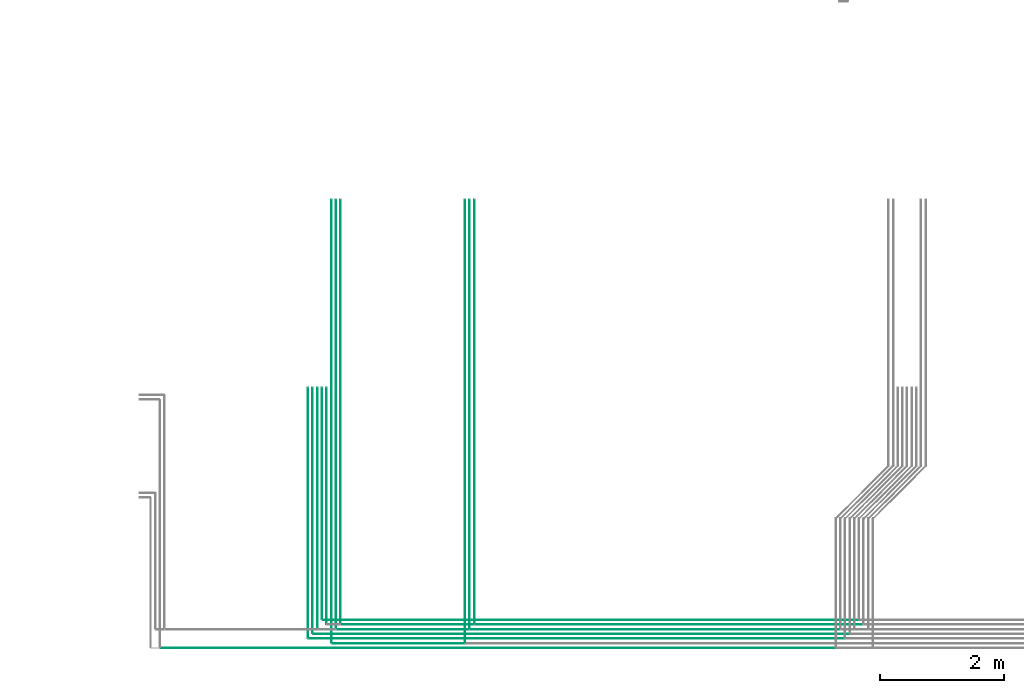
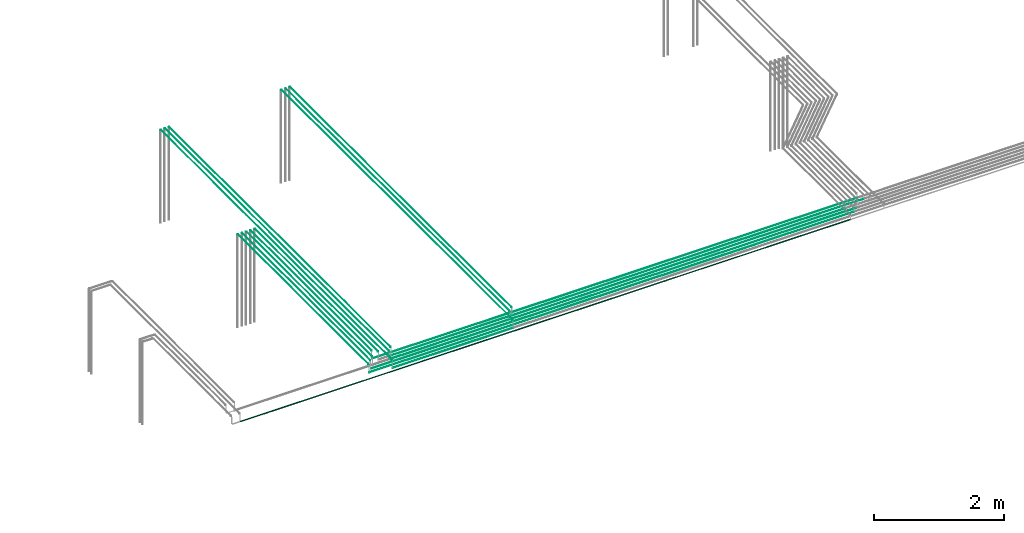
# One storey, part 3 of 89: 20 flow segments.
"""IFC2X3 building model written with IfcOpenShell, lengths in millimetres."""

from ifc_helpers import new_model, entity, si_unit, converted_unit, derived_unit, direction, frame, frame_2d, origin, origin_2d_with_axis, place, context, subcontext, project, spatial, circle, extrude, type_object, element, save


model = new_model("IFC2X3")

# Units and contexts
model_context = context("Model", 3, precision=0.01, world=origin(), true_north=direction((6.12303176911189e-17, 1.0)))
body_context = subcontext(model_context, "Body", "Model", "MODEL_VIEW")
ifc_project = project(units=[si_unit("LENGTHUNIT", "METRE", prefix="MILLI"), si_unit("AREAUNIT", "SQUARE_METRE"), si_unit("VOLUMEUNIT", "CUBIC_METRE"), converted_unit("PLANEANGLEUNIT", "DEGREE", entity("IfcRatioMeasure", 0.0174532925199433), si_unit("PLANEANGLEUNIT", "RADIAN"), dimensions=[0, 0, 0, 0, 0, 0, 0]), si_unit("MASSUNIT", "GRAM", prefix="KILO"), derived_unit("MASSDENSITYUNIT", [(si_unit("MASSUNIT", "GRAM", prefix="KILO"), 1), (si_unit("LENGTHUNIT", "METRE"), -3)]), derived_unit("MOMENTOFINERTIAUNIT", [(si_unit("LENGTHUNIT", "METRE"), 4)]), si_unit("TIMEUNIT", "SECOND"), si_unit("FREQUENCYUNIT", "HERTZ"), si_unit("THERMODYNAMICTEMPERATUREUNIT", "DEGREE_CELSIUS"), derived_unit("THERMALTRANSMITTANCEUNIT", [(si_unit("MASSUNIT", "GRAM", prefix="KILO"), 1), (si_unit("THERMODYNAMICTEMPERATUREUNIT", "KELVIN"), -1), (si_unit("TIMEUNIT", "SECOND"), -3)]), derived_unit("VOLUMETRICFLOWRATEUNIT", [(si_unit("LENGTHUNIT", "METRE"), 3), (si_unit("TIMEUNIT", "SECOND"), -1)]), derived_unit("MASSFLOWRATEUNIT", [(si_unit("MASSUNIT", "GRAM", prefix="KILO"), 1), (si_unit("TIMEUNIT", "SECOND"), -1)]), derived_unit("ROTATIONALFREQUENCYUNIT", [(si_unit("TIMEUNIT", "SECOND"), -1)]), si_unit("ELECTRICCURRENTUNIT", "AMPERE"), si_unit("ELECTRICVOLTAGEUNIT", "VOLT"), si_unit("POWERUNIT", "WATT"), si_unit("FORCEUNIT", "NEWTON", prefix="KILO"), si_unit("ILLUMINANCEUNIT", "LUX"), si_unit("LUMINOUSFLUXUNIT", "LUMEN"), si_unit("LUMINOUSINTENSITYUNIT", "CANDELA"), derived_unit("USERDEFINED", [(si_unit("MASSUNIT", "GRAM", prefix="KILO"), -1), (si_unit("LENGTHUNIT", "METRE"), -2), (si_unit("TIMEUNIT", "SECOND"), 3), (si_unit("LUMINOUSFLUXUNIT", "LUMEN"), 1)]), derived_unit("LINEARVELOCITYUNIT", [(si_unit("LENGTHUNIT", "METRE"), 1), (si_unit("TIMEUNIT", "SECOND"), -1)]), si_unit("PRESSUREUNIT", "PASCAL"), derived_unit("USERDEFINED", [(si_unit("LENGTHUNIT", "METRE"), -2), (si_unit("MASSUNIT", "GRAM", prefix="KILO"), 1), (si_unit("TIMEUNIT", "SECOND"), -2)]), derived_unit("LINEARFORCEUNIT", [(si_unit("MASSUNIT", "GRAM", prefix="KILO"), 1), (si_unit("LENGTHUNIT", "METRE"), 1), (si_unit("TIMEUNIT", "SECOND"), -2), (si_unit("LENGTHUNIT", "METRE"), -1)]), derived_unit("PLANARFORCEUNIT", [(si_unit("MASSUNIT", "GRAM", prefix="KILO"), 1), (si_unit("LENGTHUNIT", "METRE"), 1), (si_unit("TIMEUNIT", "SECOND"), -2), (si_unit("LENGTHUNIT", "METRE"), -2)])], contexts=[model_context])

# Site, building, storey
site_placement = place(None, frame((0.0, -0.00077364408347762, 0.0)))
site = spatial("IfcSite", under=ifc_project, at=site_placement, CompositionType="ELEMENT")
building_placement = place(site_placement, origin())
building = spatial("IfcBuilding", under=site, at=building_placement, CompositionType="ELEMENT")
storey_placement = place(building_placement, frame((0.0, 0.0, 24000.0)))
storey = spatial("IfcBuildingStorey", under=building, at=storey_placement, CompositionType="ELEMENT", Elevation=24000.0)

# Flow segments
pipe_segment_type = type_object("IfcPipeSegmentType", PredefinedType="NOTDEFINED")
flow_segment_1_placement = place(storey_placement, frame((44870.5982478344, 1259.95129953582, 3144.40472776409)))
element("IfcFlowSegment", 1, at=flow_segment_1_placement, inside=storey, type_object=pipe_segment_type, context=body_context, shape_type="SweptSolid", body=[
    extrude(circle(Radius=4.0, at=frame_2d((-8.66293703438714e-12, 0.0), x_axis=(1.0, 0.0))), frame((5.59527223591499, 0.0, 5.59527223591499), z_axis=(0.0, 1.0, 0.0), x_axis=(-1.0, 0.0, 0.0)), (0.0, 0.0, 1.0), 7130.03793179007),
])
flow_segment_2_placement = place(storey_placement, frame((45020.5981151137, 1559.95129953584, 3144.40472776409)))
element("IfcFlowSegment", 2, at=flow_segment_2_placement, inside=storey, type_object=pipe_segment_type, context=body_context, shape_type="SweptSolid", body=[
    extrude(circle(Radius=4.0, at=origin_2d_with_axis()), frame((5.59527223591499, 0.0, 5.59527223591499), z_axis=(0.0, 1.0, 0.0), x_axis=(-1.0, 0.0, 0.0)), (0.0, 0.0, 1.0), 6830.03793179005),
])
flow_segment_3_placement = place(storey_placement, frame((44795.5981151137, 1559.95129953584, 3144.40472776409)))
element("IfcFlowSegment", 3, at=flow_segment_3_placement, inside=storey, type_object=pipe_segment_type, context=body_context, shape_type="SweptSolid", body=[
    extrude(circle(Radius=4.0, at=origin_2d_with_axis()), frame((5.59527223591499, 0.0, 5.59527223591499), z_axis=(0.0, 1.0, 0.0), x_axis=(1.0, 0.0, 0.0)), (0.0, 0.0, 1.0), 3800.0530383061),
])
flow_segment_4_placement = place(storey_placement, frame((44495.5981151137, 1334.95129953586, 3144.40472776409)))
element("IfcFlowSegment", 4, at=flow_segment_4_placement, inside=storey, type_object=pipe_segment_type, context=body_context, shape_type="SweptSolid", body=[
    extrude(circle(Radius=4.0, at=origin_2d_with_axis()), frame((5.59527223591499, 0.0, 5.59527223591499), z_axis=(0.0, 1.0, 0.0), x_axis=(1.0, 0.0, 0.0)), (0.0, 0.0, 1.0), 4025.05303830608),
])
flow_segment_5_placement = place(storey_placement, frame((44570.5981151137, 1409.95129953583, 3144.40472776409)))
element("IfcFlowSegment", 5, at=flow_segment_5_placement, inside=storey, type_object=pipe_segment_type, context=body_context, shape_type="SweptSolid", body=[
    extrude(circle(Radius=4.0, at=origin_2d_with_axis()), frame((5.59527223591499, 0.0, 5.59527223591499), z_axis=(0.0, 1.0, 0.0), x_axis=(1.0, 0.0, 0.0)), (0.0, 0.0, 1.0), 3950.05303830611),
])
flow_segment_6_placement = place(storey_placement, frame((44645.5981151137, 1484.95129953586, 3144.40472776409)))
element("IfcFlowSegment", 6, at=flow_segment_6_placement, inside=storey, type_object=pipe_segment_type, context=body_context, shape_type="SweptSolid", body=[
    extrude(circle(Radius=4.0, at=origin_2d_with_axis()), frame((5.59527223591499, 0.0, 5.59527223591499), z_axis=(0.0, 1.0, 0.0), x_axis=(1.0, 0.0, 0.0)), (0.0, 0.0, 1.0), 3875.05303830608),
])
flow_segment_7_placement = place(storey_placement, frame((44720.5981151137, 1634.95129953587, 3144.40472776409)))
element("IfcFlowSegment", 7, at=flow_segment_7_placement, inside=storey, type_object=pipe_segment_type, context=body_context, shape_type="SweptSolid", body=[
    extrude(circle(Radius=4.0, at=origin_2d_with_axis()), frame((5.59527223591499, 0.0, 5.59527223591499), z_axis=(0.0, 1.0, 0.0), x_axis=(1.0, 0.0, 0.0)), (0.0, 0.0, 1.0), 3725.05303830606),
])
flow_segment_8_placement = place(storey_placement, frame((44945.5981151137, 1484.95129953586, 3144.40472776409)))
element("IfcFlowSegment", 8, at=flow_segment_8_placement, inside=storey, type_object=pipe_segment_type, context=body_context, shape_type="SweptSolid", body=[
    extrude(circle(Radius=4.0, at=origin_2d_with_axis()), frame((5.59527223591499, 0.0, 5.59527223591499), z_axis=(0.0, 1.0, 0.0), x_axis=(-1.0, 0.0, 0.0)), (0.0, 0.0, 1.0), 6905.03793179003),
])
flow_segment_9_placement = place(storey_placement, frame((44956.1933873496, 1469.35602729994, 2994.4047277641)))
element("IfcFlowSegment", 9, at=flow_segment_9_placement, inside=storey, type_object=pipe_segment_type, context=body_context, shape_type="SweptSolid", body=[
    extrude(circle(Radius=4.0, at=frame_2d((2.70716782324598e-13, 0.0), x_axis=(1.0, 0.0))), frame((0.0, 5.59527223591607, 5.59527223591499), z_axis=(1.0, 0.0, 0.0), x_axis=(0.0, 1.0, 0.0)), (0.0, 0.0, 1.0), 2139.99999999999),
])
flow_segment_10_placement = place(storey_placement, frame((47020.5982478344, 1259.95129953582, 3144.40472776409)))
element("IfcFlowSegment", 10, at=flow_segment_10_placement, inside=storey, type_object=pipe_segment_type, context=body_context, shape_type="SweptSolid", body=[
    extrude(circle(Radius=4.0, at=frame_2d((-8.66293703438714e-12, 0.0), x_axis=(1.0, 0.0))), frame((5.59527223591499, 0.0, 5.59527223591499), z_axis=(0.0, 1.0, 0.0), x_axis=(-1.0, 0.0, 0.0)), (0.0, 0.0, 1.0), 7130.03793179006),
])
flow_segment_11_placement = place(storey_placement, frame((47170.5981151137, 1559.95129953584, 3144.40472776409)))
element("IfcFlowSegment", 11, at=flow_segment_11_placement, inside=storey, type_object=pipe_segment_type, context=body_context, shape_type="SweptSolid", body=[
    extrude(circle(Radius=4.0, at=origin_2d_with_axis()), frame((5.59527223591499, 0.0, 5.59527223591499), z_axis=(0.0, 1.0, 0.0), x_axis=(-1.0, 0.0, 0.0)), (0.0, 0.0, 1.0), 6830.03793179004),
])
flow_segment_12_placement = place(storey_placement, frame((47095.5981151137, 1484.95129953586, 3144.40472776409)))
element("IfcFlowSegment", 12, at=flow_segment_12_placement, inside=storey, type_object=pipe_segment_type, context=body_context, shape_type="SweptSolid", body=[
    extrude(circle(Radius=4.0, at=origin_2d_with_axis()), frame((5.59527223591499, 0.0, 5.59527223591499), z_axis=(0.0, 1.0, 0.0), x_axis=(-1.0, 0.0, 0.0)), (0.0, 0.0, 1.0), 6905.03793179003),
])
flow_segment_13_placement = place(storey_placement, frame((42128.1085348189, 1165.8560272999, 2990.90472776407)))
element("IfcFlowSegment", 13, at=flow_segment_13_placement, inside=storey, type_object=pipe_segment_type, context=body_context, shape_type="SweptSolid", body=[
    extrude(circle(Radius=7.5, at=origin_2d_with_axis()), frame((0.0, 9.09527223591609, 9.09527223591419), z_axis=(1.0, 0.0, 0.0), x_axis=(0.0, -1.0, 0.0)), (0.0, 0.0, 1.0), 10855.0848525307),
])
flow_segment_14_placement = place(storey_placement, frame((44511.1933873496, 1319.35602729994, 2994.40472776408)))
element("IfcFlowSegment", 14, at=flow_segment_14_placement, inside=storey, type_object=pipe_segment_type, context=body_context, shape_type="SweptSolid", body=[
    extrude(circle(Radius=4.0, at=origin_2d_with_axis()), frame((0.0, 5.5952722359158, 5.59527223591499), z_axis=(1.0, 0.0, 0.0), x_axis=(0.0, -1.0, 0.0)), (0.0, 0.0, 1.0), 8625.00000000001),
])
flow_segment_15_placement = place(storey_placement, frame((44586.1933873496, 1394.35602729991, 2994.40472776408)))
element("IfcFlowSegment", 15, at=flow_segment_15_placement, inside=storey, type_object=pipe_segment_type, context=body_context, shape_type="SweptSolid", body=[
    extrude(circle(Radius=4.0, at=origin_2d_with_axis()), frame((0.0, 5.5952722359158, 5.59527223591499), z_axis=(1.0, 0.0, 0.0), x_axis=(0.0, -1.0, 0.0)), (0.0, 0.0, 1.0), 8625.40729350945),
])
flow_segment_16_placement = place(storey_placement, frame((44736.1933873496, 1619.35602729996, 2994.40472776408)))
element("IfcFlowSegment", 16, at=flow_segment_16_placement, inside=storey, type_object=pipe_segment_type, context=body_context, shape_type="SweptSolid", body=[
    extrude(circle(Radius=4.0, at=origin_2d_with_axis()), frame((0.0, 5.5952722359158, 5.59527223591499), z_axis=(1.0, 0.0, 0.0), x_axis=(0.0, -1.0, 0.0)), (0.0, 0.0, 1.0), 8625.00000000001),
])
flow_segment_17_placement = place(storey_placement, frame((47181.1933873496, 1544.35602729992, 2994.40472776409)))
element("IfcFlowSegment", 17, at=flow_segment_17_placement, inside=storey, type_object=pipe_segment_type, context=body_context, shape_type="SweptSolid", body=[
    extrude(circle(Radius=4.0, at=origin_2d_with_axis()), frame((0.0, 5.59527223591634, 5.59527223591499), z_axis=(1.0, 0.0, 0.0), x_axis=(0.0, -1.0, 0.0)), (0.0, 0.0, 1.0), 6255.00000000002),
])
flow_segment_18_placement = place(storey_placement, frame((44886.1935200703, 1244.35602729991, 2994.40472776409)))
element("IfcFlowSegment", 18, at=flow_segment_18_placement, inside=storey, type_object=pipe_segment_type, context=body_context, shape_type="SweptSolid", body=[
    extrude(circle(Radius=4.0, at=origin_2d_with_axis()), frame((0.0, 5.5952722359158, 5.59527223591499), z_axis=(1.0, 0.0, 0.0), x_axis=(0.0, -1.0, 0.0)), (0.0, 0.0, 1.0), 2135.0),
])
flow_segment_19_placement = place(storey_placement, frame((47106.1933873496, 1469.35602729994, 2994.40472776409)))
element("IfcFlowSegment", 19, at=flow_segment_19_placement, inside=storey, type_object=pipe_segment_type, context=body_context, shape_type="SweptSolid", body=[
    extrude(circle(Radius=4.0, at=frame_2d((2.70716782324598e-12, 0.0), x_axis=(1.0, 0.0))), frame((0.0, 5.59527223591797, 5.59527223591499), z_axis=(1.0, 0.0, 0.0), x_axis=(0.0, 1.0, 0.0)), (0.0, 0.0, 1.0), 5955.0),
])
flow_segment_20_placement = place(storey_placement, frame((45031.1933873496, 1544.35602729992, 2994.40472776409)))
element("IfcFlowSegment", 20, at=flow_segment_20_placement, inside=storey, type_object=pipe_segment_type, context=body_context, shape_type="SweptSolid", body=[
    extrude(circle(Radius=4.0, at=origin_2d_with_axis()), frame((0.0, 5.5952722359158, 5.59527223591499), z_axis=(1.0, 0.0, 0.0), x_axis=(0.0, -1.0, 0.0)), (0.0, 0.0, 1.0), 2140.0),
])

save(model, "model.ifc")
